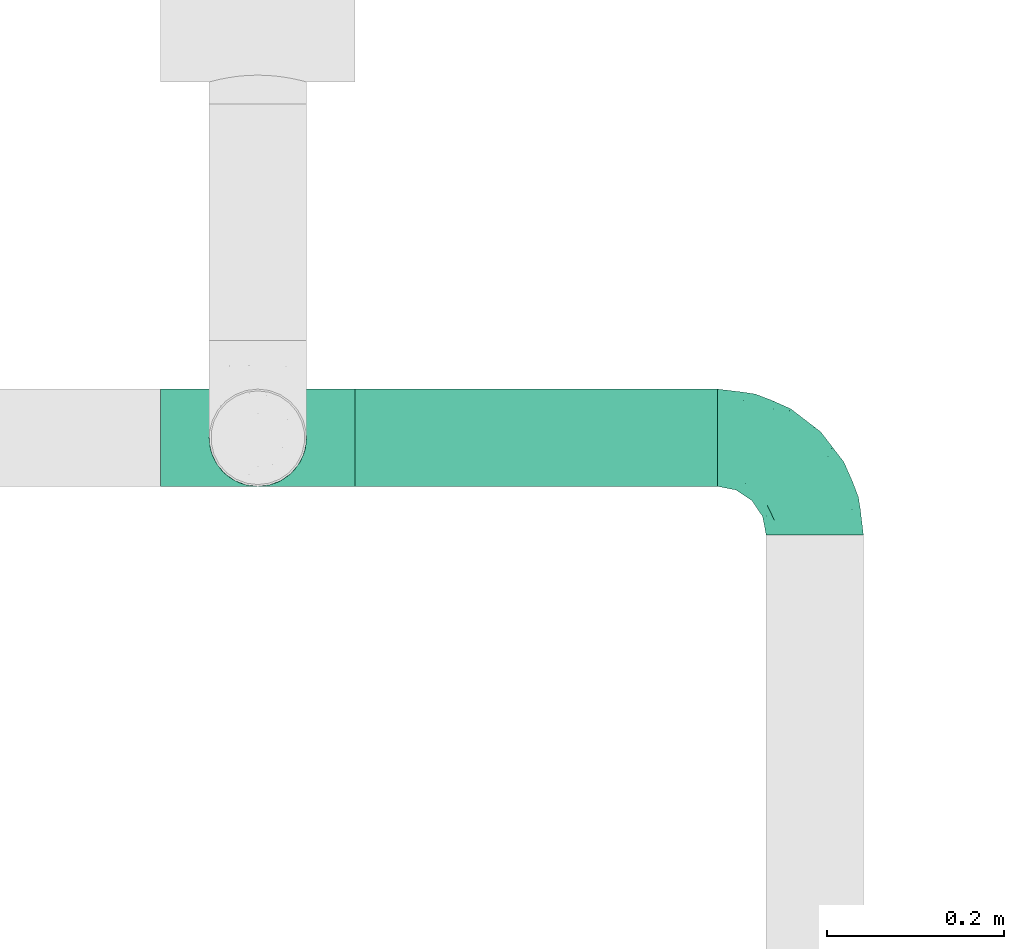
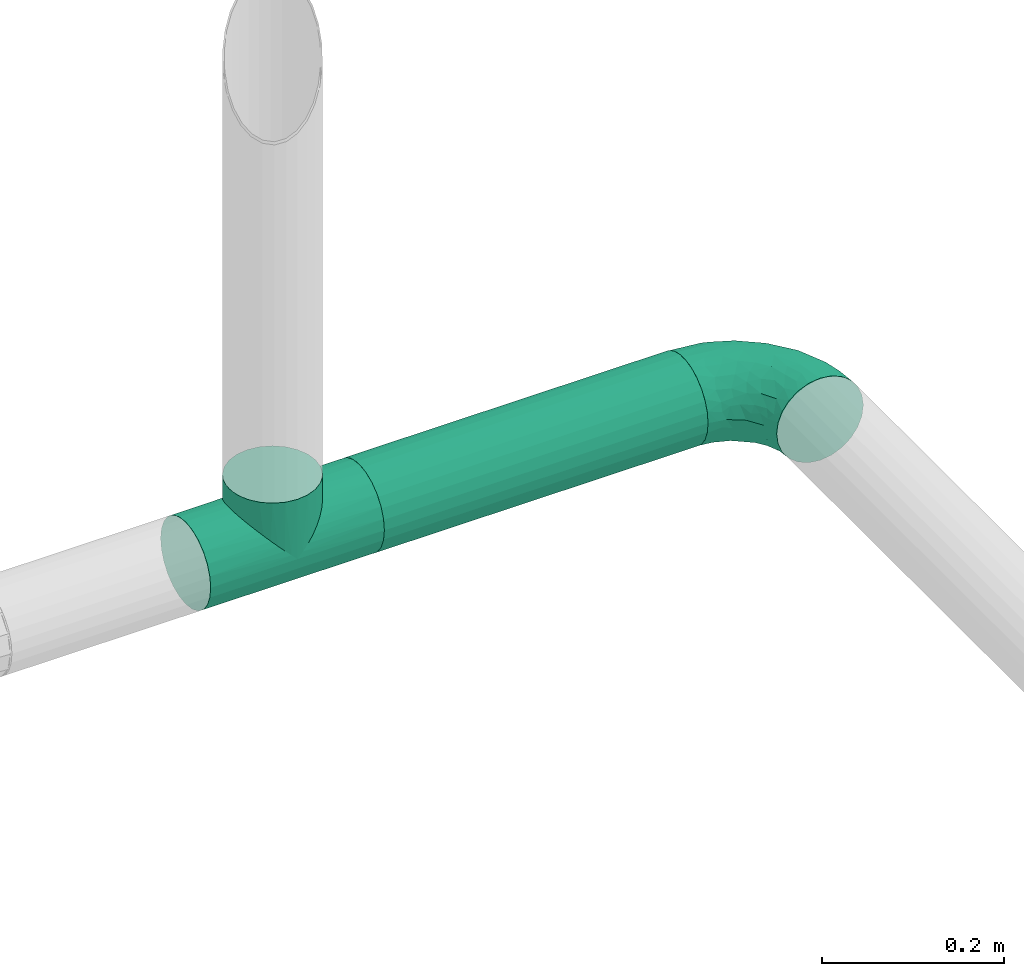
# One storey, part 79 of 103: 2 flow fittings, 1 flow segment.
"""IFC2X3 building model written with IfcOpenShell, lengths in millimetres."""

from ifc_helpers import new_model, entity, si_unit, converted_unit, derived_unit, direction, frame, origin_with_axes, origin_2d_with_axis, place, context, subcontext, project, spatial, hollow_circle, extrude, open_shell, surface_model, source, transform, mapped, material, layer, layer_set, layer_usage, type_object, element, save


model = new_model("IFC2X3")

# Units and contexts
model_context = context("Model", 3, precision=1e-05, world=origin_with_axes(), true_north=direction((0.0, 1.0)))
body_context = subcontext(model_context, "Body", "Model", "MODEL_VIEW")
ifc_project = project(units=[si_unit("AREAUNIT", "SQUARE_METRE"), si_unit("VOLUMEUNIT", "CUBIC_METRE", prefix="DECI"), si_unit("TIMEUNIT", "SECOND"), si_unit("THERMODYNAMICTEMPERATUREUNIT", "DEGREE_CELSIUS"), si_unit("PRESSUREUNIT", "PASCAL"), si_unit("MASSUNIT", "GRAM", prefix="KILO"), si_unit("LENGTHUNIT", "METRE", prefix="MILLI"), si_unit("POWERUNIT", "WATT"), si_unit("ELECTRICCURRENTUNIT", "AMPERE"), si_unit("ELECTRICVOLTAGEUNIT", "VOLT"), derived_unit("VOLUMETRICFLOWRATEUNIT", [(si_unit("VOLUMEUNIT", "CUBIC_METRE", prefix="DECI"), 1), (si_unit("TIMEUNIT", "SECOND"), -1)]), derived_unit("LINEARVELOCITYUNIT", [(si_unit("LENGTHUNIT", "METRE"), 1), (si_unit("TIMEUNIT", "SECOND"), -1)]), derived_unit("MASSDENSITYUNIT", [(si_unit("MASSUNIT", "GRAM", prefix="KILO"), 1), (si_unit("VOLUMEUNIT", "CUBIC_METRE"), -1)]), converted_unit("PLANEANGLEUNIT", "DEGREE", entity("IfcRatioMeasure", 0.01745), si_unit("PLANEANGLEUNIT", "RADIAN"), dimensions=[0, 0, 0, 0, 0, 0, 0])], contexts=[model_context])

# Site, building, storey
site_placement = place(None, origin_with_axes())
site = spatial("IfcSite", under=ifc_project, at=site_placement, CompositionType="ELEMENT")
building_placement = place(site_placement, origin_with_axes())
building = spatial("IfcBuilding", under=site, at=building_placement, Name="mc-building", CompositionType="ELEMENT")
storey_placement = place(building_placement, frame((0.0, 0.0, 5900.0), z_axis=(0.0, 0.0, 1.0), x_axis=(1.0, 0.0, 0.0)))
storey = spatial("IfcBuildingStorey", under=building, at=storey_placement, Name="3. Korrus", CompositionType="ELEMENT", Elevation=5900.0)

# Flow fittings
duct_fitting_type_1 = type_object("IfcDuctFittingType", PredefinedType="JUNCTION")
shared_shape_1 = source(origin_with_axes(), body_context, "Body", "SurfaceModel", [
    surface_model("IfcShellBasedSurfaceModel", [(0.0, -80.0, -55.0), (14.23505, -80.0, -53.12592), (-14.23505, -80.0, -53.12592), (-53.12592, -80.0, 14.23505), (-27.5, -80.0, -47.63139), (-47.63139, -80.0, -27.5), (-38.89087, -80.0, -38.89087), (55.0, -80.0, 0.0), (53.12592, -80.0, 14.23505), (38.89087, -80.0, -38.89087), (27.5, -80.0, -47.63139), (53.12592, -80.0, -14.23505), (47.63139, -80.0, -27.5), (-53.12592, -80.0, -14.23505), (-47.63139, -80.0, 27.5), (-38.89087, -80.0, 38.89087), (14.23505, -80.0, 53.12592), (-27.5, -80.0, 47.63139), (-14.23505, -80.0, 53.12592), (47.63139, -80.0, 27.5), (38.89087, -80.0, 38.89087), (27.5, -80.0, 47.63139), (0.0, -80.0, 55.0), (-55.0, -80.0, 0.0), (0.0, 0.0, 55.0), (-7.4066, -7.4066, 54.49901), (-14.74521, -14.74521, 52.98659), (-21.93978, -21.93978, 50.43457), (-28.89905, -28.89905, 46.79578), (-35.50357, -35.50357, 42.00591), (-41.58668, -41.58668, 35.99373), (-46.92319, -46.92319, 28.69171), (-51.19777, -51.19777, 20.0945), (-50.37866, -80.0, 20.86752), (-54.01174, -54.01174, 10.37938), (-55.0, -55.0, 0.0), (-54.06296, -80.0, 7.11752), (-54.01174, -54.01174, -10.37938), (-51.19777, -51.19777, -20.0945), (-54.06296, -80.0, -7.11752), (-46.92319, -46.92319, -28.69171), (-41.58668, -41.58668, -35.99373), (-50.37866, -80.0, -20.86752), (-35.50357, -35.50357, -42.00591), (-21.93978, -21.93978, -50.43457), (-14.74521, -14.74521, -52.98659), (-7.4066, -7.4066, -54.49901), (0.0, 0.0, -55.0), (-28.89905, -28.89905, -46.79578), (7.4066, -7.4066, -54.49901), (14.74521, -14.74521, -52.98659), (21.93978, -21.93978, -50.43457), (28.89905, -28.89905, -46.79578), (35.50357, -35.50357, -42.00591), (41.58668, -41.58668, -35.99373), (46.92319, -46.92319, -28.69171), (51.19777, -51.19777, -20.0945), (50.37866, -80.0, -20.86752), (54.01174, -54.01174, -10.37938), (55.0, -55.0, 0.0), (54.06296, -80.0, -7.11752), (54.01174, -54.01174, 10.37938), (51.19777, -51.19777, 20.0945), (54.06296, -80.0, 7.11752), (46.92319, -46.92319, 28.69171), (41.58668, -41.58668, 35.99373), (50.37866, -80.0, 20.86752), (35.50357, -35.50357, 42.00591), (21.93978, -21.93978, 50.43457), (14.74521, -14.74521, 52.98659), (7.4066, -7.4066, 54.49901), (28.89905, -28.89905, 46.79578), (-110.0, 0.0, -55.0), (-110.0, -14.23505, -53.12592), (-110.0, 14.23505, -53.12592), (-110.0, 53.12592, 14.23505), (-110.0, 27.5, -47.63139), (-110.0, 47.63139, -27.5), (-110.0, 38.89087, -38.89087), (-110.0, -55.0, 0.0), (-110.0, -53.12592, 14.23505), (-110.0, -38.89087, -38.89087), (-110.0, -27.5, -47.63139), (-110.0, -53.12592, -14.23505), (-110.0, -47.63139, -27.5), (-110.0, 53.12592, -14.23505), (-110.0, 47.63139, 27.5), (-110.0, 38.89087, 38.89087), (-110.0, -14.23505, 53.12592), (-110.0, 27.5, 47.63139), (-110.0, 14.23505, 53.12592), (-110.0, -47.63139, 27.5), (-110.0, -38.89087, 38.89087), (-110.0, -27.5, 47.63139), (-110.0, 0.0, 55.0), (-110.0, 55.0, 0.0), (110.0, 55.0, 0.0), (110.0, 0.0, -55.0), (110.0, 14.23505, -53.12592), (110.0, 27.5, -47.63139), (110.0, 38.89087, -38.89087), (110.0, 47.63139, -27.5), (110.0, -38.89087, -38.89087), (110.0, -53.12592, 14.23505), (110.0, -27.5, -47.63139), (110.0, -14.23505, -53.12592), (110.0, -47.63139, -27.5), (110.0, -53.12592, -14.23505), (110.0, -55.0, 0.0), (110.0, 53.12592, -14.23505), (110.0, 53.12592, 14.23505), (110.0, 47.63139, 27.5), (110.0, 38.89087, 38.89087), (110.0, 0.0, 55.0), (110.0, 27.5, 47.63139), (110.0, 14.23505, 53.12592), (110.0, -47.63139, 27.5), (110.0, -38.89087, 38.89087), (110.0, -27.5, 47.63139), (110.0, -14.23505, 53.12592)], [open_shell([[[0, 1, 2]], [[2, 3, 4]], [[5, 6, 3]], [[6, 4, 3]], [[2, 7, 8]], [[9, 7, 10]], [[1, 10, 7]], [[11, 7, 12]], [[9, 12, 7]], [[7, 2, 1]], [[5, 3, 13]], [[2, 14, 3]], [[2, 15, 14]], [[2, 16, 17]], [[17, 15, 2]], [[16, 18, 17]], [[2, 8, 19]], [[2, 19, 20]], [[2, 20, 21]], [[16, 2, 21]], [[16, 22, 18]], [[23, 13, 3]], [[24, 25, 22]], [[26, 27, 18]], [[25, 26, 18]], [[22, 25, 18]], [[17, 28, 29]], [[17, 18, 27]], [[17, 29, 15]], [[28, 17, 27]], [[30, 31, 14]], [[32, 3, 33]], [[32, 34, 3]], [[35, 36, 34]], [[31, 32, 14]], [[15, 30, 14]], [[34, 36, 3]], [[33, 14, 32]], [[36, 35, 23]], [[30, 15, 29]], [[37, 38, 13]], [[37, 13, 39]], [[40, 41, 5]], [[38, 5, 42]], [[38, 40, 5]], [[37, 39, 35]], [[35, 39, 23]], [[13, 38, 42]], [[41, 6, 5]], [[41, 43, 6]], [[44, 45, 2]], [[46, 47, 0]], [[45, 46, 2]], [[43, 48, 4]], [[44, 4, 48]], [[44, 2, 4]], [[46, 0, 2]], [[43, 4, 6]], [[47, 49, 0]], [[50, 51, 1]], [[49, 50, 1]], [[0, 49, 1]], [[10, 52, 53]], [[10, 1, 51]], [[10, 53, 9]], [[52, 10, 51]], [[54, 55, 12]], [[56, 11, 57]], [[56, 58, 11]], [[59, 60, 58]], [[55, 56, 12]], [[9, 54, 12]], [[58, 60, 11]], [[57, 12, 56]], [[60, 59, 7]], [[54, 9, 53]], [[61, 62, 8]], [[61, 8, 63]], [[64, 65, 19]], [[62, 19, 66]], [[62, 64, 19]], [[61, 63, 59]], [[7, 59, 63]], [[62, 66, 8]], [[65, 20, 19]], [[65, 67, 20]], [[68, 69, 16]], [[70, 24, 22]], [[69, 70, 16]], [[67, 71, 21]], [[68, 21, 71]], [[68, 16, 21]], [[70, 22, 16]], [[67, 21, 20]], [[72, 73, 74]], [[74, 75, 76]], [[77, 78, 75]], [[76, 75, 78]], [[74, 79, 80]], [[81, 79, 82]], [[73, 82, 79]], [[83, 79, 84]], [[81, 84, 79]], [[79, 74, 73]], [[77, 75, 85]], [[74, 86, 75]], [[74, 87, 86]], [[74, 88, 89]], [[89, 87, 74]], [[88, 90, 89]], [[74, 91, 92]], [[91, 74, 80]], [[92, 93, 74]], [[74, 93, 88]], [[88, 94, 90]], [[95, 85, 75]], [[96, 97, 98]], [[99, 96, 98]], [[96, 100, 101]], [[100, 96, 99]], [[102, 97, 103]], [[97, 102, 104]], [[104, 105, 97]], [[102, 103, 106]], [[106, 103, 107]], [[108, 107, 103]], [[109, 96, 101]], [[110, 111, 97]], [[97, 111, 112]], [[113, 97, 114]], [[97, 112, 114]], [[113, 114, 115]], [[116, 103, 97]], [[117, 116, 97]], [[118, 117, 97]], [[119, 118, 97]], [[119, 97, 113]], [[96, 110, 97]], [[24, 113, 115]], [[89, 115, 114]], [[94, 24, 90]], [[90, 24, 115]], [[115, 89, 90]], [[114, 87, 89]], [[86, 112, 111]], [[75, 111, 110]], [[95, 110, 96]], [[87, 112, 86]], [[86, 111, 75]], [[110, 95, 75]], [[112, 87, 114]], [[85, 96, 109]], [[77, 109, 101]], [[95, 96, 85]], [[85, 109, 77]], [[101, 78, 77]], [[101, 100, 78]], [[76, 100, 99]], [[74, 99, 98]], [[47, 98, 97]], [[76, 99, 74]], [[47, 72, 74]], [[98, 47, 74]], [[100, 76, 78]], [[47, 46, 72]], [[45, 44, 73]], [[46, 45, 73]], [[72, 46, 73]], [[82, 48, 43]], [[82, 73, 44]], [[82, 43, 81]], [[48, 82, 44]], [[41, 40, 84]], [[38, 37, 83]], [[40, 38, 84]], [[81, 41, 84]], [[37, 79, 83]], [[83, 84, 38]], [[79, 37, 35]], [[41, 81, 43]], [[49, 97, 105]], [[105, 104, 51]], [[53, 104, 102]], [[53, 52, 104]], [[49, 47, 97]], [[51, 50, 105]], [[52, 51, 104]], [[49, 105, 50]], [[54, 102, 106]], [[56, 106, 107]], [[58, 107, 108]], [[55, 54, 106]], [[58, 56, 107]], [[59, 58, 108]], [[55, 106, 56]], [[102, 54, 53]], [[34, 32, 80]], [[31, 30, 91]], [[32, 31, 91]], [[35, 34, 79]], [[80, 79, 34]], [[32, 91, 80]], [[30, 92, 91]], [[30, 29, 92]], [[27, 26, 88]], [[25, 24, 94]], [[26, 25, 88]], [[29, 28, 93]], [[27, 93, 28]], [[27, 88, 93]], [[25, 94, 88]], [[29, 93, 92]], [[61, 108, 103]], [[62, 103, 116]], [[65, 116, 117]], [[61, 59, 108]], [[64, 62, 116]], [[65, 64, 116]], [[61, 103, 62]], [[117, 67, 65]], [[71, 67, 118]], [[118, 67, 117]], [[68, 118, 119]], [[70, 119, 113]], [[68, 71, 118]], [[70, 69, 119]], [[24, 70, 113]], [[68, 119, 69]]])]),
])
flow_fitting_1_placement = place(storey_placement, frame((25672.59509, 9477.62755, 2345.0), z_axis=(0.0, 1.0, 0.0), x_axis=(1.0, 0.0, 0.0)))
element("IfcFlowFitting", 1, at=flow_fitting_1_placement, inside=storey, type_object=duct_fitting_type_1, context=body_context, shape_type="MappedRepresentation", body=[
    mapped(shared_shape_1, transform((0.0, 0.0, 0.0), scale=1.0)),
])
duct_fitting_type_2 = type_object("IfcDuctFittingType", Name="BU", PredefinedType="BEND")
shared_shape_2 = source(origin_with_axes(), body_context, "Body", "SurfaceModel", [
    surface_model("IfcShellBasedSurfaceModel", [(-110.0, 0.0, -55.0), (-110.0, -14.23505, -53.12592), (-110.0, 14.23505, -53.12592), (-110.0, 53.12592, 14.23505), (-110.0, 27.5, -47.63139), (-110.0, 38.89087, -38.89087), (-110.0, -55.0, 0.0), (-110.0, -53.12592, 14.23505), (-110.0, -38.89087, -38.89087), (-110.0, -27.5, -47.63139), (-110.0, -53.12592, -14.23505), (-110.0, -47.63139, -27.5), (-110.0, -14.23505, 53.12592), (-110.0, 14.23505, 53.12592), (-110.0, 27.5, 47.63139), (-110.0, -47.63139, 27.5), (-110.0, -38.89087, 38.89087), (-110.0, -27.5, 47.63139), (-110.0, 0.0, 55.0), (-110.0, 55.0, 0.0), (-110.0, 53.12592, -14.23505), (-110.0, 47.63139, -27.5), (-110.0, 47.63139, 27.5), (-110.0, 38.89087, 38.89087), (-14.23505, 110.0, -53.12592), (-55.0, 110.0, 0.0), (0.0, 110.0, -55.0), (-27.5, 110.0, -47.63139), (-38.89087, 110.0, -38.89087), (-47.63139, 110.0, -27.5), (38.89087, 110.0, -38.89087), (53.12592, 110.0, 14.23505), (27.5, 110.0, -47.63139), (14.23505, 110.0, -53.12592), (47.63139, 110.0, -27.5), (53.12592, 110.0, -14.23505), (55.0, 110.0, 0.0), (-53.12592, 110.0, -14.23505), (-53.12592, 110.0, 14.23505), (-47.63139, 110.0, 27.5), (-38.89087, 110.0, 38.89087), (-27.5, 110.0, 47.63139), (0.0, 110.0, 55.0), (-14.23505, 110.0, 53.12592), (38.89087, 110.0, 38.89087), (47.63139, 110.0, 27.5), (27.5, 110.0, 47.63139), (14.23505, 110.0, 53.12592), (-64.21732, 48.68956, 43.63444), (-76.6405, 38.18013, 45.55988), (-60.44912, 32.56953, 51.94617), (-76.00813, 5.38378, 55.0), (-90.15553, 11.94394, 54.09138), (-78.5998, 26.77405, 50.81338), (-70.18771, 18.55163, 54.03432), (-75.55424, 54.2118, 32.41257), (-93.27622, 45.77614, 33.48188), (-96.12334, 22.13664, 50.81337), (-21.00813, 45.34362, 55.0), (-18.36258, 70.48427, 54.04484), (-32.04182, 59.64019, 52.24446), (-63.88653, 74.77858, 17.99134), (-74.66383, 63.08407, 19.92123), (-63.60674, 66.07878, 29.97482), (-99.597, 52.72185, 18.52927), (-93.11138, 56.59448, 10.50359), (-98.21577, 57.34403, 0.0), (-53.42855, 92.60092, 21.04759), (-88.54852, 54.8376, 21.04759), (-11.86161, 90.23965, 54.10313), (-5.38378, 76.00813, 55.0), (-57.34403, 98.21577, 0.0), (-56.64619, 93.12774, 10.22088), (-45.34362, 21.00813, 55.0), (-44.60838, 44.60838, 52.13415), (-92.68484, 35.46673, 43.63443), (-22.25266, 95.40765, 50.81337), (-35.97783, 90.61597, 43.63443), (-43.70931, 69.58671, 44.47149), (-27.23711, 77.39884, 50.81337), (-57.2828, 79.3123, 24.9774), (-58.67786, 84.31125, 16.04456), (-82.93277, 60.36161, 12.91784), (-49.88337, 54.51816, 47.224), (-74.57753, 66.83759, 9.55742), (-45.35812, 94.97281, 33.48188), (-59.18663, 88.95241, 0.0), (-51.517, 78.6292, 33.48188), (-65.14788, 80.03077, 0.0), (-56.45322, 62.06476, 39.63545), (-88.95241, 59.18663, 0.0), (-71.10913, 71.10913, 0.0), (-80.03077, 65.14788, 0.0), (-94.9309, 45.36788, -33.48188), (-93.11358, 56.60141, -10.46614), (-99.64997, 52.79499, -18.30015), (-90.20425, 36.08686, -43.63443), (-79.99933, 46.56772, -37.92748), (-76.00813, 5.38378, -55.0), (-72.75364, 19.68651, -53.60527), (-45.34362, 21.00813, -55.0), (-21.91957, 65.12078, -53.85897), (-5.38378, 76.00813, -55.0), (-21.00813, 45.34362, -55.0), (-35.41876, 92.89265, -43.63443), (-91.10309, 11.02766, -54.21832), (-45.77614, 93.27622, -33.48188), (-90.50474, 23.21022, -50.81337), (-70.92854, 33.31794, -49.51754), (-78.52933, 63.35627, -11.73997), (-24.91508, 84.05606, -50.81337), (-88.78941, 54.74452, -21.04759), (-69.59921, 57.34866, -33.48187), (-73.36422, 62.46673, -22.94182), (-63.49062, 67.59111, -28.46929), (-56.59448, 93.11138, -10.50359), (-54.8376, 88.54852, -21.04759), (-54.10679, 75.85581, -32.31867), (-57.75956, 31.09612, -52.80882), (-52.72185, 99.597, -18.52927), (-12.62913, 89.46304, -53.99097), (-34.46825, 66.46123, -50.04329), (-43.9837, 43.9837, -52.42279), (-65.78527, 72.58348, -17.68796), (-70.34468, 43.65295, -44.21951), (-57.47001, 51.99467, -44.91465), (-60.72547, 82.29174, -12.88567), (-42.34915, 74.24548, -43.63444), (-57.25194, 63.5016, -38.08211), (-80.95344, 53.56991, -29.32027), (-52.32891, 4.55257, -54.0482), (32.52942, 47.13398, -30.48571), (14.88266, 20.92917, -33.7947), (14.95561, 36.05775, -42.26543), (30.24048, 70.09027, -41.7461), (19.3559, 65.35825, -48.00507), (-70.35075, -46.44478, -19.5952), (-47.13398, -32.52942, -30.48571), (-28.49299, -30.5778, -16.4009), (-4.55257, 52.32891, -54.0482), (-22.4954, 22.4954, -53.25347), (-75.47368, -11.22546, -52.60718), (-81.32209, -51.5606, -9.98467), (-80.81763, -41.84862, -32.14655), (-70.09027, -30.24048, -41.7461), (-36.05774, -14.95561, -42.26543), (-9.15831, -10.852, -27.8997), (-65.35825, -19.3559, -48.00507), (11.22546, 75.47368, -52.60718), (3.94376, 43.9333, -50.53315), (-13.39742, 13.39743, -48.13058), (-43.9333, -3.94376, -50.53315), (49.37776, 67.29486, 0.0), (41.8609, 47.82256, -9.92641), (50.20582, 74.51695, -9.9731), (18.93131, 11.7156, -17.56239), (-27.5, -32.89419, 0.0), (-1.23348, -12.25375, -12.18106), (41.84862, 80.81763, -32.14655), (35.70604, 41.31408, -20.38235), (46.44478, 70.35075, -19.5952), (32.89419, 27.5, 0.0), (6.67262, -6.67262, 0.0), (-67.29486, -49.37776, 0.0), (-50.36265, -42.95545, -9.51562), (-5.47251, 5.47251, -39.92906), (-70.35075, -46.44478, 19.5952), (-74.51695, -50.20582, 9.9731), (-41.31407, -35.70604, 20.38235), (-47.13398, -32.52942, 30.48571), (-80.81763, -41.84862, 32.14655), (-4.55257, 52.32891, 54.0482), (11.22546, 75.47368, 52.60718), (-43.9333, -3.94376, 50.53315), (-65.35825, -19.3559, 48.00507), (-36.05774, -14.95561, 42.26543), (-70.09027, -30.24048, 41.7461), (-11.7156, -18.93131, 17.56239), (30.5778, 28.49299, 16.4009), (12.25375, 1.23348, 12.18106), (51.5606, 81.32209, 9.98467), (42.95545, 50.36265, 9.51562), (-75.47368, -11.22546, 52.60718), (-52.32891, 4.55257, 54.0482), (3.94376, 43.9333, 50.53315), (-22.4954, 22.4954, 53.25347), (-13.39742, 13.39743, 48.13058), (10.852, 9.15831, 27.8997), (-20.92916, -14.88266, 33.79469), (-47.82256, -41.8609, 9.92641), (32.52942, 47.13398, 30.48571), (46.44478, 70.35075, 19.5952), (41.84862, 80.81763, 32.14655), (30.24048, 70.09027, 41.7461), (19.3559, 65.35825, 48.00507), (14.95561, 36.05775, 42.26543), (-5.47251, 5.47251, 39.92906)], [open_shell([[[0, 1, 2]], [[2, 3, 4]], [[4, 3, 5]], [[2, 6, 7]], [[8, 6, 9]], [[1, 9, 6]], [[10, 6, 11]], [[8, 11, 6]], [[6, 2, 1]], [[12, 13, 14]], [[15, 2, 7]], [[16, 17, 2]], [[2, 17, 12]], [[12, 18, 13]], [[19, 20, 3]], [[5, 3, 21]], [[20, 21, 3]], [[22, 3, 2]], [[23, 22, 2]], [[12, 14, 2]], [[2, 14, 23]], [[15, 16, 2]], [[24, 25, 26]], [[27, 25, 24]], [[25, 28, 29]], [[28, 25, 27]], [[30, 26, 31]], [[26, 30, 32]], [[32, 33, 26]], [[34, 31, 35]], [[31, 34, 30]], [[35, 31, 36]], [[29, 37, 25]], [[38, 39, 26]], [[39, 40, 26]], [[41, 42, 40]], [[42, 26, 40]], [[42, 41, 43]], [[26, 44, 45]], [[31, 26, 45]], [[26, 46, 44]], [[47, 46, 26]], [[42, 47, 26]], [[25, 38, 26]], [[48, 49, 50]], [[18, 51, 52]], [[53, 54, 50]], [[55, 56, 49]], [[56, 22, 23]], [[13, 57, 14]], [[58, 59, 60]], [[61, 62, 63]], [[3, 64, 65]], [[53, 52, 54]], [[3, 65, 66]], [[67, 39, 38]], [[56, 68, 64]], [[65, 64, 68]], [[69, 59, 70]], [[38, 71, 72]], [[73, 58, 74]], [[75, 49, 56]], [[76, 69, 43]], [[53, 57, 52]], [[77, 78, 79]], [[41, 76, 43]], [[43, 69, 42]], [[55, 68, 56]], [[23, 14, 75]], [[76, 77, 79]], [[80, 67, 81]], [[62, 82, 68]], [[60, 78, 83]], [[62, 84, 82]], [[85, 77, 40]], [[81, 67, 72]], [[86, 72, 71]], [[87, 85, 67]], [[61, 81, 88]], [[77, 41, 40]], [[78, 77, 87]], [[23, 75, 56]], [[83, 89, 48]], [[85, 40, 39]], [[62, 68, 55]], [[89, 87, 63]], [[83, 48, 50]], [[57, 75, 14]], [[49, 75, 53]], [[67, 85, 39]], [[87, 77, 85]], [[63, 62, 55]], [[89, 55, 48]], [[80, 63, 87]], [[66, 65, 90]], [[66, 19, 3]], [[84, 91, 92]], [[92, 90, 82]], [[65, 82, 90]], [[61, 84, 62]], [[92, 82, 84]], [[68, 82, 65]], [[3, 22, 64]], [[56, 64, 22]], [[38, 25, 71]], [[81, 72, 86]], [[38, 72, 67]], [[91, 61, 88]], [[80, 81, 61]], [[63, 80, 61]], [[67, 80, 87]], [[77, 76, 41]], [[79, 59, 69]], [[79, 69, 76]], [[42, 69, 70]], [[60, 59, 79]], [[58, 70, 59]], [[78, 60, 79]], [[58, 60, 74]], [[52, 57, 13]], [[75, 57, 53]], [[18, 52, 13]], [[52, 51, 54]], [[51, 73, 54]], [[50, 73, 74]], [[73, 50, 54]], [[50, 74, 83]], [[60, 83, 74]], [[89, 83, 78]], [[87, 89, 78]], [[55, 89, 63]], [[50, 49, 53]], [[55, 49, 48]], [[81, 86, 88]], [[91, 84, 61]], [[5, 21, 93]], [[90, 94, 66]], [[20, 94, 95]], [[96, 93, 97]], [[98, 99, 100]], [[96, 4, 5]], [[101, 102, 103]], [[28, 27, 104]], [[2, 105, 0]], [[104, 106, 28]], [[99, 105, 107]], [[108, 107, 96]], [[90, 109, 94]], [[107, 2, 4]], [[20, 66, 94]], [[27, 24, 110]], [[109, 111, 94]], [[112, 113, 114]], [[37, 115, 71]], [[116, 106, 117]], [[99, 118, 100]], [[116, 115, 119]], [[37, 119, 115]], [[24, 120, 110]], [[121, 110, 101]], [[119, 106, 116]], [[101, 110, 120]], [[122, 103, 100]], [[117, 123, 116]], [[124, 125, 108]], [[115, 116, 126]], [[106, 29, 28]], [[26, 102, 120]], [[127, 104, 110]], [[97, 124, 96]], [[125, 122, 118]], [[128, 127, 125]], [[96, 5, 93]], [[115, 126, 86]], [[117, 106, 127]], [[111, 113, 129]], [[95, 93, 21]], [[97, 129, 112]], [[110, 104, 27]], [[106, 104, 127]], [[96, 107, 4]], [[99, 107, 108]], [[99, 108, 118]], [[105, 99, 98]], [[112, 114, 128]], [[121, 125, 127]], [[20, 19, 66]], [[109, 90, 92]], [[94, 111, 95]], [[91, 123, 109]], [[129, 113, 112]], [[93, 95, 111]], [[21, 20, 95]], [[71, 115, 86]], [[71, 25, 37]], [[123, 91, 88]], [[126, 116, 123]], [[123, 88, 126]], [[86, 126, 88]], [[37, 29, 119]], [[106, 119, 29]], [[129, 93, 111]], [[124, 112, 125]], [[0, 105, 98]], [[107, 105, 2]], [[125, 118, 108]], [[100, 118, 122]], [[93, 129, 97]], [[113, 111, 109]], [[109, 123, 113]], [[114, 123, 117]], [[123, 114, 113]], [[128, 114, 117]], [[127, 128, 117]], [[112, 128, 125]], [[103, 122, 101]], [[110, 121, 127]], [[101, 122, 121]], [[125, 121, 122]], [[26, 120, 24]], [[101, 120, 102]], [[96, 124, 108]], [[92, 91, 109]], [[112, 124, 97]], [[100, 130, 98]], [[131, 132, 133]], [[32, 134, 135]], [[136, 137, 138]], [[139, 140, 103]], [[98, 141, 0]], [[142, 10, 136]], [[143, 144, 137]], [[6, 10, 142]], [[137, 145, 146]], [[144, 147, 145]], [[143, 136, 11]], [[11, 136, 10]], [[8, 143, 11]], [[148, 149, 139]], [[8, 9, 144]], [[9, 1, 147]], [[130, 141, 98]], [[103, 140, 100]], [[148, 135, 149]], [[150, 151, 140]], [[152, 153, 154]], [[130, 140, 151]], [[148, 26, 33]], [[147, 1, 141]], [[155, 146, 132]], [[156, 138, 157]], [[134, 30, 158]], [[150, 140, 149]], [[158, 30, 34]], [[30, 134, 32]], [[153, 159, 160]], [[131, 160, 159]], [[144, 145, 137]], [[36, 152, 154]], [[146, 138, 137]], [[155, 161, 162]], [[158, 160, 131]], [[133, 149, 135]], [[156, 163, 164]], [[163, 142, 164]], [[139, 103, 102]], [[153, 152, 161]], [[34, 35, 160]], [[162, 157, 155]], [[132, 165, 133]], [[157, 146, 155]], [[140, 130, 100]], [[141, 130, 151]], [[141, 151, 147]], [[141, 1, 0]], [[102, 26, 148]], [[140, 139, 149]], [[102, 148, 139]], [[135, 33, 32]], [[151, 150, 145]], [[9, 147, 144]], [[151, 145, 147]], [[145, 165, 146]], [[135, 148, 33]], [[133, 135, 134]], [[131, 133, 134]], [[133, 165, 150]], [[133, 150, 149]], [[145, 150, 165]], [[132, 131, 159]], [[146, 165, 132]], [[160, 158, 34]], [[134, 158, 131]], [[144, 143, 8]], [[136, 143, 137]], [[155, 153, 161]], [[154, 153, 160]], [[153, 155, 159]], [[132, 159, 155]], [[160, 35, 154]], [[36, 154, 35]], [[164, 136, 138]], [[6, 142, 163]], [[136, 164, 142]], [[156, 164, 138]], [[156, 157, 162]], [[146, 157, 138]], [[15, 7, 166]], [[6, 163, 167]], [[168, 169, 166]], [[166, 169, 170]], [[171, 172, 70]], [[173, 174, 175]], [[17, 176, 174]], [[177, 156, 162]], [[176, 16, 170]], [[170, 16, 15]], [[161, 178, 179]], [[152, 180, 181]], [[182, 173, 183]], [[18, 12, 182]], [[184, 185, 186]], [[183, 185, 73]], [[183, 73, 51]], [[177, 187, 188]], [[189, 168, 166]], [[187, 178, 190]], [[16, 176, 17]], [[161, 152, 181]], [[45, 191, 31]], [[45, 44, 192]], [[192, 191, 45]], [[180, 36, 31]], [[193, 194, 195]], [[46, 47, 194]], [[193, 195, 190]], [[193, 44, 46]], [[172, 42, 70]], [[185, 58, 73]], [[189, 163, 156]], [[163, 189, 167]], [[70, 58, 171]], [[184, 171, 185]], [[169, 188, 175]], [[180, 31, 191]], [[192, 193, 190]], [[191, 190, 178]], [[182, 174, 173]], [[194, 47, 172]], [[190, 195, 187]], [[186, 185, 173]], [[162, 179, 177]], [[188, 196, 175]], [[179, 187, 177]], [[185, 171, 58]], [[172, 171, 184]], [[172, 184, 194]], [[172, 47, 42]], [[51, 18, 182]], [[185, 183, 173]], [[51, 182, 183]], [[174, 12, 17]], [[184, 186, 195]], [[46, 194, 193]], [[184, 195, 194]], [[195, 196, 187]], [[174, 182, 12]], [[175, 174, 176]], [[169, 175, 176]], [[175, 196, 186]], [[175, 186, 173]], [[195, 186, 196]], [[188, 169, 168]], [[187, 196, 188]], [[166, 170, 15]], [[176, 170, 169]], [[193, 192, 44]], [[191, 192, 190]], [[177, 189, 156]], [[167, 189, 166]], [[189, 177, 168]], [[188, 168, 177]], [[166, 7, 167]], [[6, 167, 7]], [[181, 191, 178]], [[36, 180, 152]], [[191, 181, 180]], [[161, 181, 178]], [[161, 179, 162]], [[187, 179, 178]]])]),
])
flow_fitting_2_placement = place(storey_placement, frame((26302.64841, 9477.62755, 2345.0), z_axis=(0.0, 0.0, 1.0), x_axis=(0.0, 1.0, 0.0)))
element("IfcFlowFitting", 2, at=flow_fitting_2_placement, inside=storey, type_object=duct_fitting_type_2, Name="BU", context=body_context, shape_type="MappedRepresentation", body=[
    mapped(shared_shape_2, transform((0.0, 0.0, 0.0), scale=1.0)),
])

# Flow segment
ifc_material = material(Name="FZ1")
ifc_layer = layer(ifc_material, 0.0)
ifc_layer_set = layer_set([ifc_layer], Name="FZ1")
ifc_layer_usage = layer_usage(ifc_layer_set, "AXIS1", "POSITIVE", 0.0)
duct_segment_type = type_object("IfcDuctSegmentType", Name="Safe", PredefinedType="RIGIDSEGMENT")
shared_shape_3 = source(origin_with_axes(), body_context, "Body", "SweptSolid", [
    extrude(hollow_circle(Radius=55.0, WallThickness=2.0, at=origin_2d_with_axis()), frame((0.0, 0.0, 0.0), z_axis=(1.0, 0.0, 0.0), x_axis=(0.0, 1.0, 0.0)), (0.0, 0.0, 1.0), 410.1),
])
flow_segment_placement = place(storey_placement, frame((26192.64841, 9477.62755, 2345.0), z_axis=(0.0, 0.0, 1.0), x_axis=(-1.0, 0.0, 0.0)))
element("IfcFlowSegment", 3, at=flow_segment_placement, inside=storey, type_object=duct_segment_type, material=ifc_layer_usage, Name="Safe", context=body_context, shape_type="MappedRepresentation", body=[
    mapped(shared_shape_3, transform((0.0, 0.0, 0.0), scale=1.0)),
])

save(model, "model.ifc")
